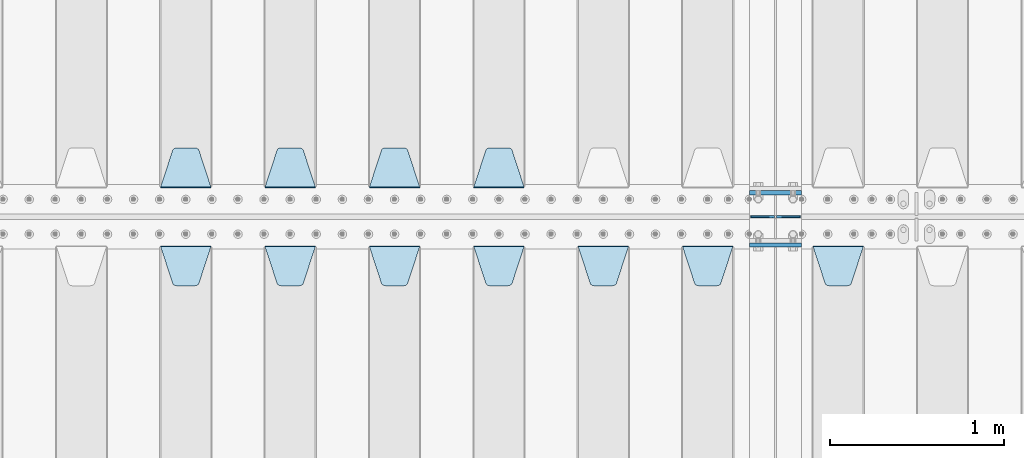
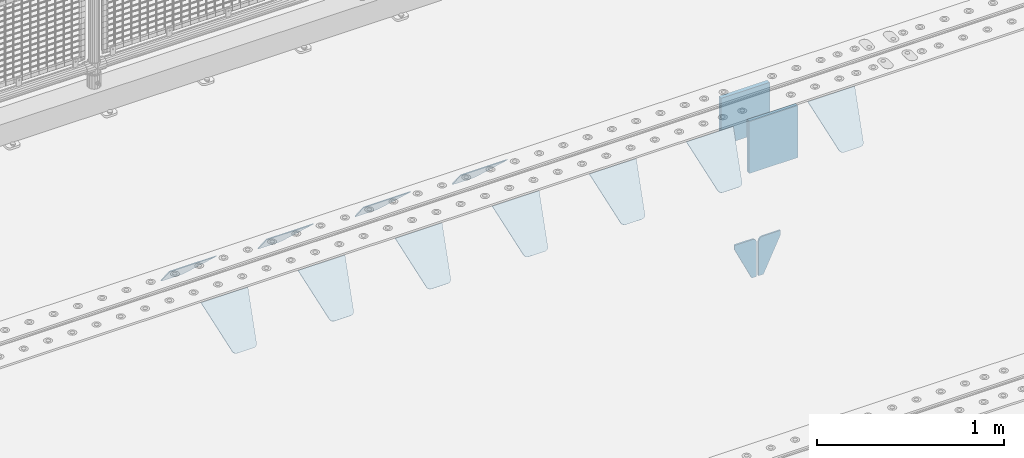
# One storey, part 188 of 219: 15 plates.
"""IFC2X3 building model written with IfcOpenShell, lengths in millimetres."""

from ifc_helpers import new_model, si_unit, frame, origin_with_axes, place, context, subcontext, project, spatial, faceted_brep, material, type_object, element, save


model = new_model("IFC2X3")

# Units and contexts
model_context = context("Model", 3, precision=1e-05, world=origin_with_axes())
body_context = subcontext(model_context, "Body", "Model", "MODEL_VIEW")
ifc_project = project(units=[si_unit("LENGTHUNIT", "METRE", prefix="MILLI"), si_unit("AREAUNIT", "SQUARE_METRE"), si_unit("VOLUMEUNIT", "CUBIC_METRE"), si_unit("MASSUNIT", "GRAM", prefix="KILO"), si_unit("TIMEUNIT", "SECOND"), si_unit("PLANEANGLEUNIT", "RADIAN"), si_unit("SOLIDANGLEUNIT", "STERADIAN"), si_unit("THERMODYNAMICTEMPERATUREUNIT", "DEGREE_CELSIUS"), si_unit("LUMINOUSINTENSITYUNIT", "LUMEN")], contexts=[model_context])

# Site, building, storey
site_placement = place(None, origin_with_axes())
site = spatial("IfcSite", under=ifc_project, at=site_placement, CompositionType="ELEMENT")
building_placement = place(site_placement, origin_with_axes())
building = spatial("IfcBuilding", under=site, at=building_placement, Name="Standard", CompositionType="ELEMENT")
storey_placement = place(building_placement, origin_with_axes())
storey = spatial("IfcBuildingStorey", under=building, at=storey_placement, Name="Undefined", CompositionType="ELEMENT", Elevation=0.0)

# Plates
ifc_material = material(Name="STEEL/S355N")
plate_type_1 = type_object("IfcPlateType", PredefinedType="NOTDEFINED")
plate_1_placement = place(storey_placement, frame((10240.0, 29837.5, -340.000000000044), z_axis=(0.0, 0.0, 1.0), x_axis=(1.0, 0.0, 0.0)))
element("IfcPlate", 1, at=plate_1_placement, inside=storey, type_object=plate_type_1, material=ifc_material, context=body_context, shape_type="Brep", body=[
    faceted_brep([(0.0, -12.5, 0.0), (9.27684595808387e-10, -12.5, 340.0), (9.27684595808387e-10, 12.5, 340.0), (0.0, 12.5, 0.0), (300.0, -12.5, 340.0), (300.0, 12.5, 340.0), (300.0, -12.5, 0.0), (300.0, 12.5, 0.0)], [[[0, 1, 2, 3]], [[1, 4, 5, 2]], [[4, 6, 7, 5]], [[6, 0, 3, 7]], [[5, 7, 3, 2]], [[6, 4, 1, 0]]]),
])
plate_2_placement = place(storey_placement, frame((10240.0, 30137.5, -340.0), z_axis=(0.0, 0.0, 1.0), x_axis=(1.0, 0.0, 0.0)))
element("IfcPlate", 2, at=plate_2_placement, inside=storey, type_object=plate_type_1, material=ifc_material, context=body_context, shape_type="Brep", body=[
    faceted_brep([(0.0, -12.5, 0.0), (0.0, -12.5, 310.0), (0.0, 12.5, 310.0), (0.0, 12.5, 0.0), (300.0, -12.5, 310.0), (300.0, 12.5, 310.0), (300.0, -12.5, 0.0), (300.0, 12.5, 0.0)], [[[0, 1, 2, 3]], [[1, 4, 5, 2]], [[4, 6, 7, 5]], [[6, 0, 3, 7]], [[5, 7, 3, 2]], [[6, 4, 1, 0]]]),
])
plate_type_2 = type_object("IfcPlateType", PredefinedType="NOTDEFINED")
for number, where, z_axis, x_axis in (
    (3, (10383.5000000189, 30000.0000000149, -915.000018206196), (0.0, 0.0, -1.0), (-1.0, 0.0, 0.0)),
    (4, (10396.5000000189, 30000.0000000149, -915.000018206196), (0.0, 0.0, -1.0), (1.0, 0.0, 0.0)),
):
    element("IfcPlate", number, at=place(storey_placement, frame(where, z_axis=z_axis, x_axis=x_axis)), inside=storey, type_object=plate_type_2, material=ifc_material, context=body_context, shape_type="Brep", body=[
        faceted_brep([(0.0, -5.0, 27.0), (0.0, -5.0, 250.0), (0.0, 5.0, 250.0), (0.0, 5.0, 27.0), (30.0, -5.0, 250.0), (30.0, 5.0, 250.0), (135.0, -5.0, 30.0), (135.0, 5.0, 30.0), (135.0, -5.0, 0.0), (135.0, 5.0, 0.0), (27.0, -5.0, 0.0), (27.0, 5.0, 0.0), (22.3114992029932, -5.0, 0.410190668670339), (22.3114992029932, 5.0, 0.410190668670339), (17.7654561302061, -5.0, 1.62829923878041), (17.7654561302061, 5.0, 1.62829923878041), (13.5, -5.0, 3.61731409782021), (13.5, 5.0, 3.61731409782021), (9.64473453846404, -5.0, 6.31680003578765), (9.64473453846404, 5.0, 6.31680003578765), (6.31680003578731, -5.0, 9.64473453846347), (6.31680003578731, 5.0, 9.64473453846347), (3.61731409782078, -5.0, 13.5), (3.61731409782078, 5.0, 13.5), (1.62829923878053, -5.0, 17.765456130207), (1.62829923878053, 5.0, 17.765456130207), (0.410190668670111, -5.0, 22.3114992029929), (0.410190668670111, 5.0, 22.3114992029929)], [[[0, 1, 2, 3]], [[1, 4, 5, 2]], [[4, 6, 7, 5]], [[6, 8, 9, 7]], [[8, 10, 11, 9]], [[10, 12, 13, 11]], [[12, 14, 15, 13]], [[14, 16, 17, 15]], [[16, 18, 19, 17]], [[18, 20, 21, 19]], [[20, 22, 23, 21]], [[22, 24, 25, 23]], [[24, 26, 27, 25]], [[26, 0, 3, 27]], [[5, 7, 9, 11, 13, 15, 17, 19, 21, 23, 25, 27, 3, 2]], [[26, 24, 22, 20, 18, 16, 14, 12, 10, 8, 6, 4, 1, 0]]]),
    ])
plate_type_3 = type_object("IfcPlateType", PredefinedType="NOTDEFINED")
plate_3_placement = place(storey_placement, frame((10605.0, 29831.767766956, -1.76776695296758), z_axis=(0.0, -0.707106781186547, -0.707106781186548), x_axis=(1.0, 0.0, 0.0)))
element("IfcPlate", 5, at=plate_3_placement, inside=storey, type_object=plate_type_3, material=ifc_material, context=body_context, shape_type="Brep", body=[
    faceted_brep([(0.0, -2.5, 0.0), (69.345504679477, -2.5, 300.171731424834), (69.345504679477, 2.49999999999636, 300.171731424831), (0.0, 2.5, 0.0), (70.9274061199576, -2.50000000000364, 304.8974424154), (70.9274061199576, 2.49999999999636, 304.8974424154), (73.3818627772307, -2.50000000000364, 309.234538108532), (73.3818627772307, 2.49999999999636, 309.234538108532), (76.6187032999569, -2.50000000000364, 313.023683126106), (76.6187032999569, 2.49999999999636, 313.023683126106), (80.5190132704993, -2.50000000000364, 316.125672595372), (80.5190132704993, 2.49999999999636, 316.125672595372), (84.9395038596831, -2.50000000000364, 318.426546230476), (84.9395038596831, 2.5, 318.426546230479), (89.7177759439237, -2.50000000000364, 319.841774983277), (89.7177759439237, 2.5, 319.841774983281), (94.6782862926502, -2.50000000000364, 320.319366455078), (94.6782862926502, 2.49999999999636, 320.319366455078), (195.32171370735, -2.50000000000364, 320.319366455078), (195.32171370735, 2.49999999999636, 320.319366455078), (200.282224056076, -2.50000000000364, 319.841774983277), (200.282224056076, 2.5, 319.841774983281), (205.060496140317, -2.50000000000364, 318.426546230476), (205.060496140317, 2.49999999999636, 318.426546230476), (209.480986729501, -2.50000000000364, 316.125672595372), (209.480986729501, 2.49999999999636, 316.125672595372), (213.381296700043, -2.50000000000364, 313.023683126106), (213.381296700043, 2.49999999999272, 313.023683126106), (216.618137222769, -2.50000000000364, 309.234538108529), (216.618137222769, 2.49999999999636, 309.234538108525), (219.072593880042, -2.50000000000364, 304.8974424154), (219.072593880042, 2.49999999999636, 304.8974424154), (220.654495320523, -2.5, 300.171731424834), (220.654495320523, 2.49999999999636, 300.171731424831), (290.0, -2.50000000000364, 3.63797880709171e-12), (290.0, 2.49999999999636, 0.0)], [[[0, 1, 2, 3]], [[1, 4, 5, 2]], [[4, 6, 7, 5]], [[6, 8, 9, 7]], [[8, 10, 11, 9]], [[10, 12, 13, 11]], [[12, 14, 15, 13]], [[14, 16, 17, 15]], [[16, 18, 19, 17]], [[18, 20, 21, 19]], [[20, 22, 23, 21]], [[22, 24, 25, 23]], [[24, 26, 27, 25]], [[26, 28, 29, 27]], [[28, 30, 31, 29]], [[30, 32, 33, 31]], [[32, 34, 35, 33]], [[34, 0, 3, 35]], [[5, 7, 9, 11, 13, 15, 17, 19, 21, 23, 25, 27, 29, 31, 33, 35, 3, 2]], [[34, 32, 30, 28, 26, 24, 22, 20, 18, 16, 14, 12, 10, 8, 6, 4, 1, 0]]]),
])
plate_4_placement = place(storey_placement, frame((9855.0, 29831.767766956, -1.76776695296758), z_axis=(0.0, -0.707106781186547, -0.707106781186548), x_axis=(1.0, 0.0, 0.0)))
element("IfcPlate", 6, at=plate_4_placement, inside=storey, type_object=plate_type_3, material=ifc_material, context=body_context, shape_type="Brep", body=[
    faceted_brep([(0.0, -2.5, 0.0), (69.345504679477, -2.5, 300.171731424834), (69.345504679477, 2.49999999999636, 300.171731424831), (0.0, 2.5, 0.0), (70.9274061199576, -2.50000000000364, 304.8974424154), (70.9274061199576, 2.49999999999636, 304.8974424154), (73.3818627772307, -2.50000000000364, 309.234538108532), (73.3818627772307, 2.49999999999636, 309.234538108532), (76.6187032999569, -2.50000000000364, 313.023683126106), (76.6187032999569, 2.49999999999636, 313.023683126106), (80.5190132704993, -2.50000000000364, 316.125672595372), (80.5190132704993, 2.49999999999636, 316.125672595372), (84.9395038596831, -2.50000000000364, 318.426546230476), (84.9395038596831, 2.5, 318.426546230479), (89.7177759439237, -2.50000000000364, 319.841774983277), (89.7177759439237, 2.5, 319.841774983281), (94.6782862926502, -2.50000000000364, 320.319366455078), (94.6782862926502, 2.49999999999636, 320.319366455078), (195.32171370735, -2.50000000000364, 320.319366455078), (195.32171370735, 2.49999999999636, 320.319366455078), (200.282224056076, -2.50000000000364, 319.841774983277), (200.282224056076, 2.5, 319.841774983281), (205.060496140317, -2.50000000000364, 318.426546230476), (205.060496140317, 2.49999999999636, 318.426546230476), (209.480986729501, -2.50000000000364, 316.125672595372), (209.480986729501, 2.49999999999636, 316.125672595372), (213.381296700043, -2.50000000000364, 313.023683126106), (213.381296700043, 2.49999999999272, 313.023683126106), (216.618137222769, -2.50000000000364, 309.234538108529), (216.618137222769, 2.49999999999636, 309.234538108525), (219.072593880042, -2.50000000000364, 304.8974424154), (219.072593880042, 2.49999999999636, 304.8974424154), (220.654495320523, -2.5, 300.171731424834), (220.654495320523, 2.49999999999636, 300.171731424831), (290.0, -2.50000000000364, 3.63797880709171e-12), (290.0, 2.49999999999636, 0.0)], [[[0, 1, 2, 3]], [[1, 4, 5, 2]], [[4, 6, 7, 5]], [[6, 8, 9, 7]], [[8, 10, 11, 9]], [[10, 12, 13, 11]], [[12, 14, 15, 13]], [[14, 16, 17, 15]], [[16, 18, 19, 17]], [[18, 20, 21, 19]], [[20, 22, 23, 21]], [[22, 24, 25, 23]], [[24, 26, 27, 25]], [[26, 28, 29, 27]], [[28, 30, 31, 29]], [[30, 32, 33, 31]], [[32, 34, 35, 33]], [[34, 0, 3, 35]], [[5, 7, 9, 11, 13, 15, 17, 19, 21, 23, 25, 27, 29, 31, 33, 35, 3, 2]], [[34, 32, 30, 28, 26, 24, 22, 20, 18, 16, 14, 12, 10, 8, 6, 4, 1, 0]]]),
])
plate_5_placement = place(storey_placement, frame((9255.0, 29831.767766956, -1.76776695296758), z_axis=(0.0, -0.707106781186547, -0.707106781186548), x_axis=(1.0, 0.0, 0.0)))
element("IfcPlate", 7, at=plate_5_placement, inside=storey, type_object=plate_type_3, material=ifc_material, context=body_context, shape_type="Brep", body=[
    faceted_brep([(0.0, -2.5, 0.0), (69.345504679477, -2.5, 300.171731424834), (69.345504679477, 2.49999999999636, 300.171731424831), (0.0, 2.5, 0.0), (70.9274061199576, -2.50000000000364, 304.8974424154), (70.9274061199576, 2.49999999999636, 304.8974424154), (73.3818627772307, -2.50000000000364, 309.234538108532), (73.3818627772307, 2.49999999999636, 309.234538108532), (76.6187032999569, -2.50000000000364, 313.023683126106), (76.6187032999569, 2.49999999999636, 313.023683126106), (80.5190132704993, -2.50000000000364, 316.125672595372), (80.5190132704993, 2.49999999999636, 316.125672595372), (84.9395038596831, -2.50000000000364, 318.426546230476), (84.9395038596831, 2.5, 318.426546230479), (89.7177759439237, -2.50000000000364, 319.841774983277), (89.7177759439237, 2.5, 319.841774983281), (94.6782862926502, -2.50000000000364, 320.319366455078), (94.6782862926502, 2.49999999999636, 320.319366455078), (195.32171370735, -2.50000000000364, 320.319366455078), (195.32171370735, 2.49999999999636, 320.319366455078), (200.282224056076, -2.50000000000364, 319.841774983277), (200.282224056076, 2.5, 319.841774983281), (205.060496140317, -2.50000000000364, 318.426546230476), (205.060496140317, 2.49999999999636, 318.426546230476), (209.480986729501, -2.50000000000364, 316.125672595372), (209.480986729501, 2.49999999999636, 316.125672595372), (213.381296700043, -2.50000000000364, 313.023683126106), (213.381296700043, 2.49999999999272, 313.023683126106), (216.618137222769, -2.50000000000364, 309.234538108529), (216.618137222769, 2.49999999999636, 309.234538108525), (219.072593880042, -2.50000000000364, 304.8974424154), (219.072593880042, 2.49999999999636, 304.8974424154), (220.654495320523, -2.5, 300.171731424834), (220.654495320523, 2.49999999999636, 300.171731424831), (290.0, -2.50000000000364, 3.63797880709171e-12), (290.0, 2.49999999999636, 0.0)], [[[0, 1, 2, 3]], [[1, 4, 5, 2]], [[4, 6, 7, 5]], [[6, 8, 9, 7]], [[8, 10, 11, 9]], [[10, 12, 13, 11]], [[12, 14, 15, 13]], [[14, 16, 17, 15]], [[16, 18, 19, 17]], [[18, 20, 21, 19]], [[20, 22, 23, 21]], [[22, 24, 25, 23]], [[24, 26, 27, 25]], [[26, 28, 29, 27]], [[28, 30, 31, 29]], [[30, 32, 33, 31]], [[32, 34, 35, 33]], [[34, 0, 3, 35]], [[5, 7, 9, 11, 13, 15, 17, 19, 21, 23, 25, 27, 29, 31, 33, 35, 3, 2]], [[34, 32, 30, 28, 26, 24, 22, 20, 18, 16, 14, 12, 10, 8, 6, 4, 1, 0]]]),
])
plate_6_placement = place(storey_placement, frame((8655.0, 29831.767766956, -1.76776695296758), z_axis=(0.0, -0.707106781186547, -0.707106781186548), x_axis=(1.0, 0.0, 0.0)))
element("IfcPlate", 8, at=plate_6_placement, inside=storey, type_object=plate_type_3, material=ifc_material, context=body_context, shape_type="Brep", body=[
    faceted_brep([(0.0, -2.5, 0.0), (69.345504679477, -2.5, 300.171731424834), (69.345504679477, 2.49999999999636, 300.171731424831), (0.0, 2.5, 0.0), (70.9274061199576, -2.50000000000364, 304.8974424154), (70.9274061199576, 2.49999999999636, 304.8974424154), (73.3818627772307, -2.50000000000364, 309.234538108532), (73.3818627772307, 2.49999999999636, 309.234538108532), (76.6187032999569, -2.50000000000364, 313.023683126106), (76.6187032999569, 2.49999999999636, 313.023683126106), (80.5190132704993, -2.50000000000364, 316.125672595372), (80.5190132704993, 2.49999999999636, 316.125672595372), (84.9395038596831, -2.50000000000364, 318.426546230476), (84.9395038596831, 2.5, 318.426546230479), (89.7177759439237, -2.50000000000364, 319.841774983277), (89.7177759439237, 2.5, 319.841774983281), (94.6782862926502, -2.50000000000364, 320.319366455078), (94.6782862926502, 2.49999999999636, 320.319366455078), (195.32171370735, -2.50000000000364, 320.319366455078), (195.32171370735, 2.49999999999636, 320.319366455078), (200.282224056076, -2.50000000000364, 319.841774983277), (200.282224056076, 2.5, 319.841774983281), (205.060496140317, -2.50000000000364, 318.426546230476), (205.060496140317, 2.49999999999636, 318.426546230476), (209.480986729501, -2.50000000000364, 316.125672595372), (209.480986729501, 2.49999999999636, 316.125672595372), (213.381296700043, -2.50000000000364, 313.023683126106), (213.381296700043, 2.49999999999272, 313.023683126106), (216.618137222769, -2.50000000000364, 309.234538108529), (216.618137222769, 2.49999999999636, 309.234538108525), (219.072593880042, -2.50000000000364, 304.8974424154), (219.072593880042, 2.49999999999636, 304.8974424154), (220.654495320523, -2.5, 300.171731424834), (220.654495320523, 2.49999999999636, 300.171731424831), (290.0, -2.50000000000364, 3.63797880709171e-12), (290.0, 2.49999999999636, 0.0)], [[[0, 1, 2, 3]], [[1, 4, 5, 2]], [[4, 6, 7, 5]], [[6, 8, 9, 7]], [[8, 10, 11, 9]], [[10, 12, 13, 11]], [[12, 14, 15, 13]], [[14, 16, 17, 15]], [[16, 18, 19, 17]], [[18, 20, 21, 19]], [[20, 22, 23, 21]], [[22, 24, 25, 23]], [[24, 26, 27, 25]], [[26, 28, 29, 27]], [[28, 30, 31, 29]], [[30, 32, 33, 31]], [[32, 34, 35, 33]], [[34, 0, 3, 35]], [[5, 7, 9, 11, 13, 15, 17, 19, 21, 23, 25, 27, 29, 31, 33, 35, 3, 2]], [[34, 32, 30, 28, 26, 24, 22, 20, 18, 16, 14, 12, 10, 8, 6, 4, 1, 0]]]),
])
plate_7_placement = place(storey_placement, frame((8055.0, 29831.767766956, -1.76776695296758), z_axis=(0.0, -0.707106781186547, -0.707106781186548), x_axis=(1.0, 0.0, 0.0)))
element("IfcPlate", 9, at=plate_7_placement, inside=storey, type_object=plate_type_3, material=ifc_material, context=body_context, shape_type="Brep", body=[
    faceted_brep([(0.0, -2.5, 0.0), (69.345504679477, -2.5, 300.171731424834), (69.345504679477, 2.49999999999636, 300.171731424831), (0.0, 2.5, 0.0), (70.9274061199576, -2.50000000000364, 304.8974424154), (70.9274061199576, 2.49999999999636, 304.8974424154), (73.3818627772307, -2.50000000000364, 309.234538108532), (73.3818627772307, 2.49999999999636, 309.234538108532), (76.6187032999569, -2.50000000000364, 313.023683126106), (76.6187032999569, 2.49999999999636, 313.023683126106), (80.5190132704993, -2.50000000000364, 316.125672595372), (80.5190132704993, 2.49999999999636, 316.125672595372), (84.9395038596831, -2.50000000000364, 318.426546230476), (84.9395038596831, 2.5, 318.426546230479), (89.7177759439237, -2.50000000000364, 319.841774983277), (89.7177759439237, 2.5, 319.841774983281), (94.6782862926502, -2.50000000000364, 320.319366455078), (94.6782862926502, 2.49999999999636, 320.319366455078), (195.32171370735, -2.50000000000364, 320.319366455078), (195.32171370735, 2.49999999999636, 320.319366455078), (200.282224056076, -2.50000000000364, 319.841774983277), (200.282224056076, 2.5, 319.841774983281), (205.060496140317, -2.50000000000364, 318.426546230476), (205.060496140317, 2.49999999999636, 318.426546230476), (209.480986729501, -2.50000000000364, 316.125672595372), (209.480986729501, 2.49999999999636, 316.125672595372), (213.381296700043, -2.50000000000364, 313.023683126106), (213.381296700043, 2.49999999999272, 313.023683126106), (216.618137222769, -2.50000000000364, 309.234538108529), (216.618137222769, 2.49999999999636, 309.234538108525), (219.072593880042, -2.50000000000364, 304.8974424154), (219.072593880042, 2.49999999999636, 304.8974424154), (220.654495320523, -2.5, 300.171731424834), (220.654495320523, 2.49999999999636, 300.171731424831), (290.0, -2.50000000000364, 3.63797880709171e-12), (290.0, 2.49999999999636, 0.0)], [[[0, 1, 2, 3]], [[1, 4, 5, 2]], [[4, 6, 7, 5]], [[6, 8, 9, 7]], [[8, 10, 11, 9]], [[10, 12, 13, 11]], [[12, 14, 15, 13]], [[14, 16, 17, 15]], [[16, 18, 19, 17]], [[18, 20, 21, 19]], [[20, 22, 23, 21]], [[22, 24, 25, 23]], [[24, 26, 27, 25]], [[26, 28, 29, 27]], [[28, 30, 31, 29]], [[30, 32, 33, 31]], [[32, 34, 35, 33]], [[34, 0, 3, 35]], [[5, 7, 9, 11, 13, 15, 17, 19, 21, 23, 25, 27, 29, 31, 33, 35, 3, 2]], [[34, 32, 30, 28, 26, 24, 22, 20, 18, 16, 14, 12, 10, 8, 6, 4, 1, 0]]]),
])
plate_8_placement = place(storey_placement, frame((7455.0, 29831.767766956, -1.76776695296758), z_axis=(0.0, -0.707106781186547, -0.707106781186548), x_axis=(1.0, 0.0, 0.0)))
element("IfcPlate", 10, at=plate_8_placement, inside=storey, type_object=plate_type_3, material=ifc_material, context=body_context, shape_type="Brep", body=[
    faceted_brep([(0.0, -2.5, 0.0), (69.345504679477, -2.5, 300.171731424834), (69.345504679477, 2.49999999999636, 300.171731424831), (0.0, 2.5, 0.0), (70.9274061199576, -2.50000000000364, 304.8974424154), (70.9274061199576, 2.49999999999636, 304.8974424154), (73.3818627772307, -2.50000000000364, 309.234538108532), (73.3818627772307, 2.49999999999636, 309.234538108532), (76.6187032999569, -2.50000000000364, 313.023683126106), (76.6187032999569, 2.49999999999636, 313.023683126106), (80.5190132704993, -2.50000000000364, 316.125672595372), (80.5190132704993, 2.49999999999636, 316.125672595372), (84.9395038596831, -2.50000000000364, 318.426546230476), (84.9395038596831, 2.5, 318.426546230479), (89.7177759439237, -2.50000000000364, 319.841774983277), (89.7177759439237, 2.5, 319.841774983281), (94.6782862926502, -2.50000000000364, 320.319366455078), (94.6782862926502, 2.49999999999636, 320.319366455078), (195.32171370735, -2.50000000000364, 320.319366455078), (195.32171370735, 2.49999999999636, 320.319366455078), (200.282224056076, -2.50000000000364, 319.841774983277), (200.282224056076, 2.5, 319.841774983281), (205.060496140317, -2.50000000000364, 318.426546230476), (205.060496140317, 2.49999999999636, 318.426546230476), (209.480986729501, -2.50000000000364, 316.125672595372), (209.480986729501, 2.49999999999636, 316.125672595372), (213.381296700043, -2.50000000000364, 313.023683126106), (213.381296700043, 2.49999999999272, 313.023683126106), (216.618137222769, -2.50000000000364, 309.234538108529), (216.618137222769, 2.49999999999636, 309.234538108525), (219.072593880042, -2.50000000000364, 304.8974424154), (219.072593880042, 2.49999999999636, 304.8974424154), (220.654495320523, -2.5, 300.171731424834), (220.654495320523, 2.49999999999636, 300.171731424831), (290.0, -2.50000000000364, 3.63797880709171e-12), (290.0, 2.49999999999636, 0.0)], [[[0, 1, 2, 3]], [[1, 4, 5, 2]], [[4, 6, 7, 5]], [[6, 8, 9, 7]], [[8, 10, 11, 9]], [[10, 12, 13, 11]], [[12, 14, 15, 13]], [[14, 16, 17, 15]], [[16, 18, 19, 17]], [[18, 20, 21, 19]], [[20, 22, 23, 21]], [[22, 24, 25, 23]], [[24, 26, 27, 25]], [[26, 28, 29, 27]], [[28, 30, 31, 29]], [[30, 32, 33, 31]], [[32, 34, 35, 33]], [[34, 0, 3, 35]], [[5, 7, 9, 11, 13, 15, 17, 19, 21, 23, 25, 27, 29, 31, 33, 35, 3, 2]], [[34, 32, 30, 28, 26, 24, 22, 20, 18, 16, 14, 12, 10, 8, 6, 4, 1, 0]]]),
])
plate_9_placement = place(storey_placement, frame((6855.0, 29831.767766956, -1.76776695296758), z_axis=(0.0, -0.707106781186547, -0.707106781186548), x_axis=(1.0, 0.0, 0.0)))
element("IfcPlate", 11, at=plate_9_placement, inside=storey, type_object=plate_type_3, material=ifc_material, context=body_context, shape_type="Brep", body=[
    faceted_brep([(0.0, -2.5, 0.0), (69.345504679477, -2.5, 300.171731424834), (69.345504679477, 2.49999999999636, 300.171731424831), (0.0, 2.5, 0.0), (70.9274061199576, -2.50000000000364, 304.8974424154), (70.9274061199576, 2.49999999999636, 304.8974424154), (73.3818627772307, -2.50000000000364, 309.234538108532), (73.3818627772307, 2.49999999999636, 309.234538108532), (76.6187032999569, -2.50000000000364, 313.023683126106), (76.6187032999569, 2.49999999999636, 313.023683126106), (80.5190132704993, -2.50000000000364, 316.125672595372), (80.5190132704993, 2.49999999999636, 316.125672595372), (84.9395038596831, -2.50000000000364, 318.426546230476), (84.9395038596831, 2.5, 318.426546230479), (89.7177759439237, -2.50000000000364, 319.841774983277), (89.7177759439237, 2.5, 319.841774983281), (94.6782862926502, -2.50000000000364, 320.319366455078), (94.6782862926502, 2.49999999999636, 320.319366455078), (195.32171370735, -2.50000000000364, 320.319366455078), (195.32171370735, 2.49999999999636, 320.319366455078), (200.282224056076, -2.50000000000364, 319.841774983277), (200.282224056076, 2.5, 319.841774983281), (205.060496140317, -2.50000000000364, 318.426546230476), (205.060496140317, 2.49999999999636, 318.426546230476), (209.480986729501, -2.50000000000364, 316.125672595372), (209.480986729501, 2.49999999999636, 316.125672595372), (213.381296700043, -2.50000000000364, 313.023683126106), (213.381296700043, 2.49999999999272, 313.023683126106), (216.618137222769, -2.50000000000364, 309.234538108529), (216.618137222769, 2.49999999999636, 309.234538108525), (219.072593880042, -2.50000000000364, 304.8974424154), (219.072593880042, 2.49999999999636, 304.8974424154), (220.654495320523, -2.5, 300.171731424834), (220.654495320523, 2.49999999999636, 300.171731424831), (290.0, -2.50000000000364, 3.63797880709171e-12), (290.0, 2.49999999999636, 0.0)], [[[0, 1, 2, 3]], [[1, 4, 5, 2]], [[4, 6, 7, 5]], [[6, 8, 9, 7]], [[8, 10, 11, 9]], [[10, 12, 13, 11]], [[12, 14, 15, 13]], [[14, 16, 17, 15]], [[16, 18, 19, 17]], [[18, 20, 21, 19]], [[20, 22, 23, 21]], [[22, 24, 25, 23]], [[24, 26, 27, 25]], [[26, 28, 29, 27]], [[28, 30, 31, 29]], [[30, 32, 33, 31]], [[32, 34, 35, 33]], [[34, 0, 3, 35]], [[5, 7, 9, 11, 13, 15, 17, 19, 21, 23, 25, 27, 29, 31, 33, 35, 3, 2]], [[34, 32, 30, 28, 26, 24, 22, 20, 18, 16, 14, 12, 10, 8, 6, 4, 1, 0]]]),
])
plate_10_placement = place(storey_placement, frame((8945.0, 30168.232233047, -1.76776695296758), z_axis=(0.0, 0.707106781186547, -0.707106781186548), x_axis=(-1.0, 0.0, 0.0)))
element("IfcPlate", 12, at=plate_10_placement, inside=storey, type_object=plate_type_3, material=ifc_material, context=body_context, shape_type="Brep", body=[
    faceted_brep([(0.0, -2.5, 0.0), (69.345504679477, -2.5, 300.171731424834), (69.345504679477, 2.49999999999636, 300.171731424831), (0.0, 2.5, 0.0), (70.9274061199576, -2.50000000000364, 304.8974424154), (70.9274061199576, 2.49999999999636, 304.8974424154), (73.3818627772307, -2.50000000000364, 309.234538108532), (73.3818627772307, 2.49999999999636, 309.234538108532), (76.6187032999569, -2.50000000000364, 313.023683126106), (76.6187032999569, 2.49999999999636, 313.023683126106), (80.5190132704993, -2.50000000000364, 316.125672595372), (80.5190132704993, 2.49999999999636, 316.125672595372), (84.9395038596831, -2.50000000000364, 318.426546230476), (84.9395038596831, 2.5, 318.426546230479), (89.7177759439237, -2.50000000000364, 319.841774983277), (89.7177759439237, 2.5, 319.841774983281), (94.6782862926502, -2.50000000000364, 320.319366455078), (94.6782862926502, 2.49999999999636, 320.319366455078), (195.32171370735, -2.50000000000364, 320.319366455078), (195.32171370735, 2.49999999999636, 320.319366455078), (200.282224056076, -2.50000000000364, 319.841774983277), (200.282224056076, 2.5, 319.841774983281), (205.060496140317, -2.50000000000364, 318.426546230476), (205.060496140317, 2.49999999999636, 318.426546230476), (209.480986729501, -2.50000000000364, 316.125672595372), (209.480986729501, 2.49999999999636, 316.125672595372), (213.381296700043, -2.50000000000364, 313.023683126106), (213.381296700043, 2.49999999999272, 313.023683126106), (216.618137222769, -2.50000000000364, 309.234538108529), (216.618137222769, 2.49999999999636, 309.234538108525), (219.072593880042, -2.50000000000364, 304.8974424154), (219.072593880042, 2.49999999999636, 304.8974424154), (220.654495320523, -2.5, 300.171731424834), (220.654495320523, 2.49999999999636, 300.171731424831), (290.0, -2.50000000000364, 3.63797880709171e-12), (290.0, 2.49999999999636, 0.0)], [[[0, 1, 2, 3]], [[1, 4, 5, 2]], [[4, 6, 7, 5]], [[6, 8, 9, 7]], [[8, 10, 11, 9]], [[10, 12, 13, 11]], [[12, 14, 15, 13]], [[14, 16, 17, 15]], [[16, 18, 19, 17]], [[18, 20, 21, 19]], [[20, 22, 23, 21]], [[22, 24, 25, 23]], [[24, 26, 27, 25]], [[26, 28, 29, 27]], [[28, 30, 31, 29]], [[30, 32, 33, 31]], [[32, 34, 35, 33]], [[34, 0, 3, 35]], [[5, 7, 9, 11, 13, 15, 17, 19, 21, 23, 25, 27, 29, 31, 33, 35, 3, 2]], [[34, 32, 30, 28, 26, 24, 22, 20, 18, 16, 14, 12, 10, 8, 6, 4, 1, 0]]]),
])
plate_11_placement = place(storey_placement, frame((8345.0, 30168.232233047, -1.76776695296758), z_axis=(0.0, 0.707106781186547, -0.707106781186548), x_axis=(-1.0, 0.0, 0.0)))
element("IfcPlate", 13, at=plate_11_placement, inside=storey, type_object=plate_type_3, material=ifc_material, context=body_context, shape_type="Brep", body=[
    faceted_brep([(0.0, -2.5, 0.0), (69.345504679477, -2.5, 300.171731424834), (69.345504679477, 2.49999999999636, 300.171731424831), (0.0, 2.5, 0.0), (70.9274061199576, -2.50000000000364, 304.8974424154), (70.9274061199576, 2.49999999999636, 304.8974424154), (73.3818627772307, -2.50000000000364, 309.234538108532), (73.3818627772307, 2.49999999999636, 309.234538108532), (76.6187032999569, -2.50000000000364, 313.023683126106), (76.6187032999569, 2.49999999999636, 313.023683126106), (80.5190132704993, -2.50000000000364, 316.125672595372), (80.5190132704993, 2.49999999999636, 316.125672595372), (84.9395038596831, -2.50000000000364, 318.426546230476), (84.9395038596831, 2.5, 318.426546230479), (89.7177759439237, -2.50000000000364, 319.841774983277), (89.7177759439237, 2.5, 319.841774983281), (94.6782862926502, -2.50000000000364, 320.319366455078), (94.6782862926502, 2.49999999999636, 320.319366455078), (195.32171370735, -2.50000000000364, 320.319366455078), (195.32171370735, 2.49999999999636, 320.319366455078), (200.282224056076, -2.50000000000364, 319.841774983277), (200.282224056076, 2.5, 319.841774983281), (205.060496140317, -2.50000000000364, 318.426546230476), (205.060496140317, 2.49999999999636, 318.426546230476), (209.480986729501, -2.50000000000364, 316.125672595372), (209.480986729501, 2.49999999999636, 316.125672595372), (213.381296700043, -2.50000000000364, 313.023683126106), (213.381296700043, 2.49999999999272, 313.023683126106), (216.618137222769, -2.50000000000364, 309.234538108529), (216.618137222769, 2.49999999999636, 309.234538108525), (219.072593880042, -2.50000000000364, 304.8974424154), (219.072593880042, 2.49999999999636, 304.8974424154), (220.654495320523, -2.5, 300.171731424834), (220.654495320523, 2.49999999999636, 300.171731424831), (290.0, -2.50000000000364, 3.63797880709171e-12), (290.0, 2.49999999999636, 0.0)], [[[0, 1, 2, 3]], [[1, 4, 5, 2]], [[4, 6, 7, 5]], [[6, 8, 9, 7]], [[8, 10, 11, 9]], [[10, 12, 13, 11]], [[12, 14, 15, 13]], [[14, 16, 17, 15]], [[16, 18, 19, 17]], [[18, 20, 21, 19]], [[20, 22, 23, 21]], [[22, 24, 25, 23]], [[24, 26, 27, 25]], [[26, 28, 29, 27]], [[28, 30, 31, 29]], [[30, 32, 33, 31]], [[32, 34, 35, 33]], [[34, 0, 3, 35]], [[5, 7, 9, 11, 13, 15, 17, 19, 21, 23, 25, 27, 29, 31, 33, 35, 3, 2]], [[34, 32, 30, 28, 26, 24, 22, 20, 18, 16, 14, 12, 10, 8, 6, 4, 1, 0]]]),
])
plate_12_placement = place(storey_placement, frame((7745.0, 30168.232233047, -1.76776695296758), z_axis=(0.0, 0.707106781186547, -0.707106781186548), x_axis=(-1.0, 0.0, 0.0)))
element("IfcPlate", 14, at=plate_12_placement, inside=storey, type_object=plate_type_3, material=ifc_material, context=body_context, shape_type="Brep", body=[
    faceted_brep([(0.0, -2.5, 0.0), (69.345504679477, -2.5, 300.171731424834), (69.345504679477, 2.49999999999636, 300.171731424831), (0.0, 2.5, 0.0), (70.9274061199576, -2.50000000000364, 304.8974424154), (70.9274061199576, 2.49999999999636, 304.8974424154), (73.3818627772307, -2.50000000000364, 309.234538108532), (73.3818627772307, 2.49999999999636, 309.234538108532), (76.6187032999569, -2.50000000000364, 313.023683126106), (76.6187032999569, 2.49999999999636, 313.023683126106), (80.5190132704993, -2.50000000000364, 316.125672595372), (80.5190132704993, 2.49999999999636, 316.125672595372), (84.9395038596831, -2.50000000000364, 318.426546230476), (84.9395038596831, 2.5, 318.426546230479), (89.7177759439237, -2.50000000000364, 319.841774983277), (89.7177759439237, 2.5, 319.841774983281), (94.6782862926502, -2.50000000000364, 320.319366455078), (94.6782862926502, 2.49999999999636, 320.319366455078), (195.32171370735, -2.50000000000364, 320.319366455078), (195.32171370735, 2.49999999999636, 320.319366455078), (200.282224056076, -2.50000000000364, 319.841774983277), (200.282224056076, 2.5, 319.841774983281), (205.060496140317, -2.50000000000364, 318.426546230476), (205.060496140317, 2.49999999999636, 318.426546230476), (209.480986729501, -2.50000000000364, 316.125672595372), (209.480986729501, 2.49999999999636, 316.125672595372), (213.381296700043, -2.50000000000364, 313.023683126106), (213.381296700043, 2.49999999999272, 313.023683126106), (216.618137222769, -2.50000000000364, 309.234538108529), (216.618137222769, 2.49999999999636, 309.234538108525), (219.072593880042, -2.50000000000364, 304.8974424154), (219.072593880042, 2.49999999999636, 304.8974424154), (220.654495320523, -2.5, 300.171731424834), (220.654495320523, 2.49999999999636, 300.171731424831), (290.0, -2.50000000000364, 3.63797880709171e-12), (290.0, 2.49999999999636, 0.0)], [[[0, 1, 2, 3]], [[1, 4, 5, 2]], [[4, 6, 7, 5]], [[6, 8, 9, 7]], [[8, 10, 11, 9]], [[10, 12, 13, 11]], [[12, 14, 15, 13]], [[14, 16, 17, 15]], [[16, 18, 19, 17]], [[18, 20, 21, 19]], [[20, 22, 23, 21]], [[22, 24, 25, 23]], [[24, 26, 27, 25]], [[26, 28, 29, 27]], [[28, 30, 31, 29]], [[30, 32, 33, 31]], [[32, 34, 35, 33]], [[34, 0, 3, 35]], [[5, 7, 9, 11, 13, 15, 17, 19, 21, 23, 25, 27, 29, 31, 33, 35, 3, 2]], [[34, 32, 30, 28, 26, 24, 22, 20, 18, 16, 14, 12, 10, 8, 6, 4, 1, 0]]]),
])
plate_13_placement = place(storey_placement, frame((7145.0, 30168.232233047, -1.76776695296758), z_axis=(0.0, 0.707106781186547, -0.707106781186548), x_axis=(-1.0, 0.0, 0.0)))
element("IfcPlate", 15, at=plate_13_placement, inside=storey, type_object=plate_type_3, material=ifc_material, context=body_context, shape_type="Brep", body=[
    faceted_brep([(0.0, -2.5, 0.0), (69.345504679477, -2.5, 300.171731424834), (69.345504679477, 2.49999999999636, 300.171731424831), (0.0, 2.5, 0.0), (70.9274061199576, -2.50000000000364, 304.8974424154), (70.9274061199576, 2.49999999999636, 304.8974424154), (73.3818627772307, -2.50000000000364, 309.234538108532), (73.3818627772307, 2.49999999999636, 309.234538108532), (76.6187032999569, -2.50000000000364, 313.023683126106), (76.6187032999569, 2.49999999999636, 313.023683126106), (80.5190132704993, -2.50000000000364, 316.125672595372), (80.5190132704993, 2.49999999999636, 316.125672595372), (84.9395038596831, -2.50000000000364, 318.426546230476), (84.9395038596831, 2.5, 318.426546230479), (89.7177759439237, -2.50000000000364, 319.841774983277), (89.7177759439237, 2.5, 319.841774983281), (94.6782862926502, -2.50000000000364, 320.319366455078), (94.6782862926502, 2.49999999999636, 320.319366455078), (195.32171370735, -2.50000000000364, 320.319366455078), (195.32171370735, 2.49999999999636, 320.319366455078), (200.282224056076, -2.50000000000364, 319.841774983277), (200.282224056076, 2.5, 319.841774983281), (205.060496140317, -2.50000000000364, 318.426546230476), (205.060496140317, 2.49999999999636, 318.426546230476), (209.480986729501, -2.50000000000364, 316.125672595372), (209.480986729501, 2.49999999999636, 316.125672595372), (213.381296700043, -2.50000000000364, 313.023683126106), (213.381296700043, 2.49999999999272, 313.023683126106), (216.618137222769, -2.50000000000364, 309.234538108529), (216.618137222769, 2.49999999999636, 309.234538108525), (219.072593880042, -2.50000000000364, 304.8974424154), (219.072593880042, 2.49999999999636, 304.8974424154), (220.654495320523, -2.5, 300.171731424834), (220.654495320523, 2.49999999999636, 300.171731424831), (290.0, -2.50000000000364, 3.63797880709171e-12), (290.0, 2.49999999999636, 0.0)], [[[0, 1, 2, 3]], [[1, 4, 5, 2]], [[4, 6, 7, 5]], [[6, 8, 9, 7]], [[8, 10, 11, 9]], [[10, 12, 13, 11]], [[12, 14, 15, 13]], [[14, 16, 17, 15]], [[16, 18, 19, 17]], [[18, 20, 21, 19]], [[20, 22, 23, 21]], [[22, 24, 25, 23]], [[24, 26, 27, 25]], [[26, 28, 29, 27]], [[28, 30, 31, 29]], [[30, 32, 33, 31]], [[32, 34, 35, 33]], [[34, 0, 3, 35]], [[5, 7, 9, 11, 13, 15, 17, 19, 21, 23, 25, 27, 29, 31, 33, 35, 3, 2]], [[34, 32, 30, 28, 26, 24, 22, 20, 18, 16, 14, 12, 10, 8, 6, 4, 1, 0]]]),
])

save(model, "model.ifc")
